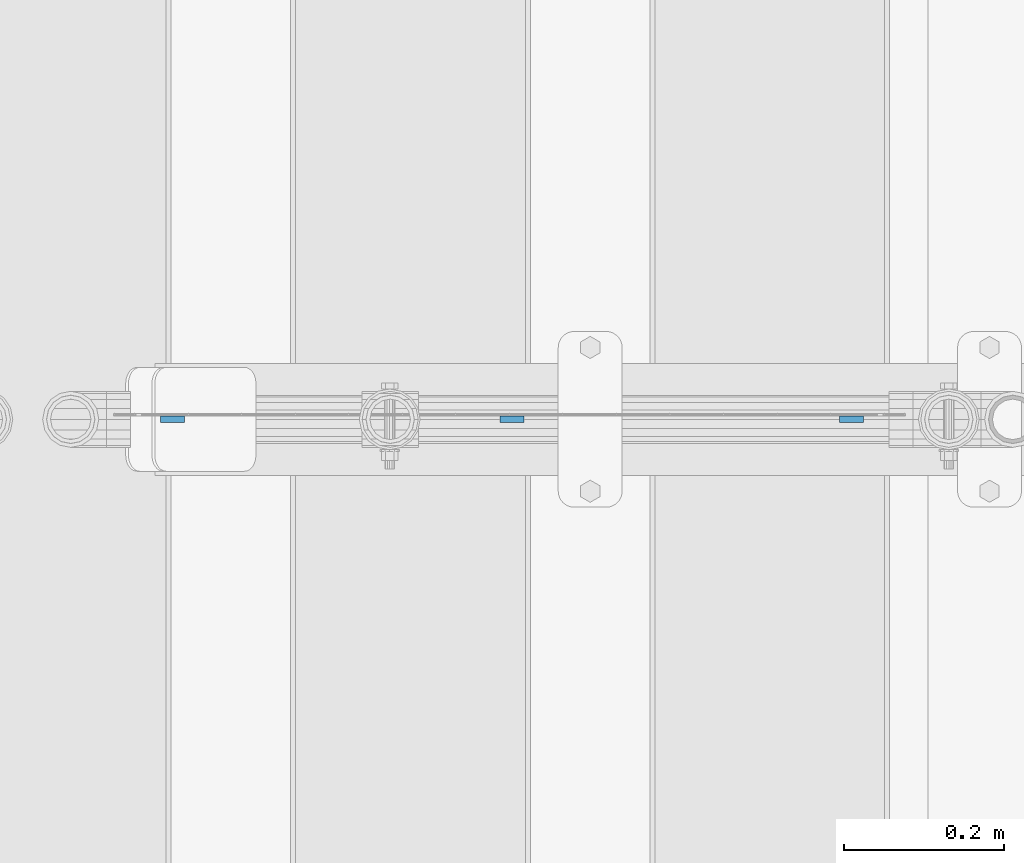
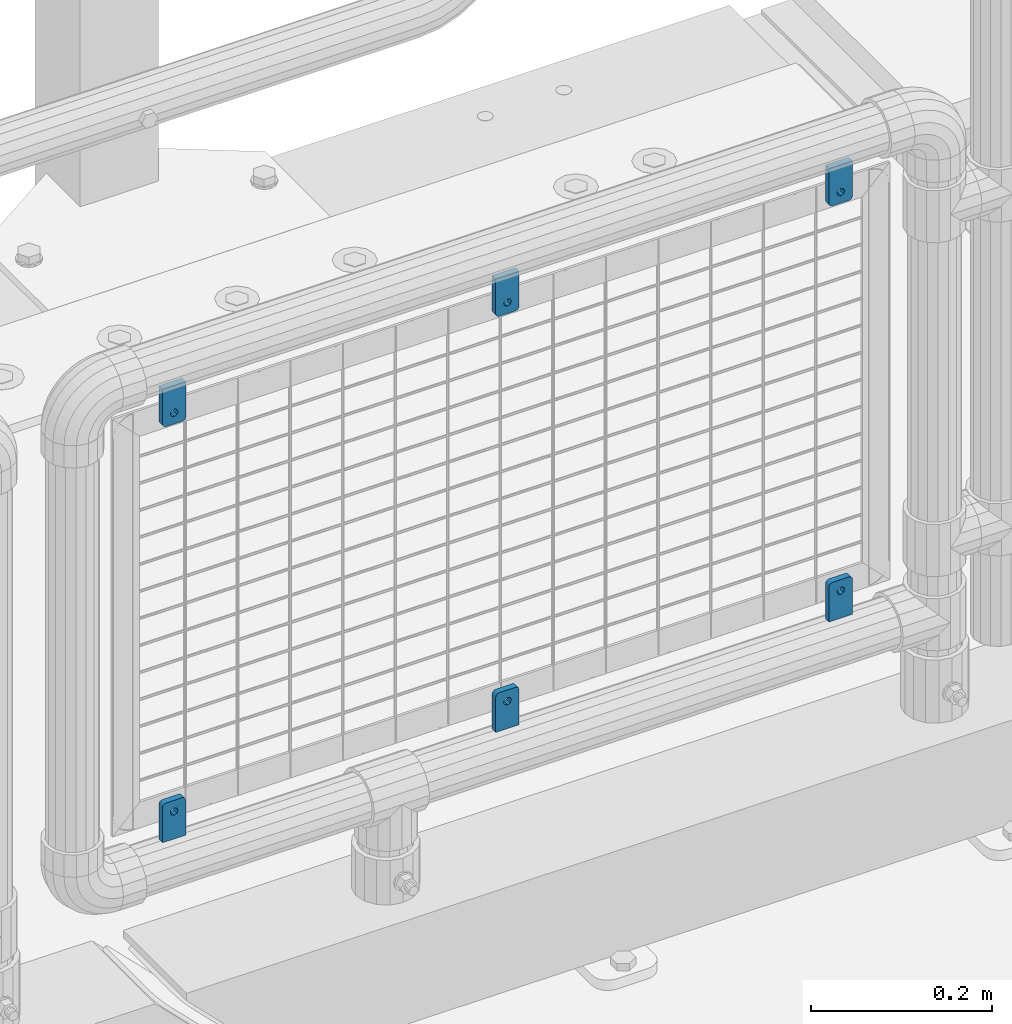
# One storey, part 266 of 270: 6 plates.
"""IFC2X3 building model written with IfcOpenShell, lengths in millimetres."""

from ifc_helpers import new_model, si_unit, frame, origin_with_axes, place, context, subcontext, project, spatial, faceted_brep, material, type_object, element, save


model = new_model("IFC2X3")

# Units and contexts
model_context = context("Model", 3, precision=1e-05, world=origin_with_axes())
body_context = subcontext(model_context, "Body", "Model", "MODEL_VIEW")
ifc_project = project(units=[si_unit("LENGTHUNIT", "METRE", prefix="MILLI"), si_unit("AREAUNIT", "SQUARE_METRE"), si_unit("VOLUMEUNIT", "CUBIC_METRE"), si_unit("MASSUNIT", "GRAM", prefix="KILO"), si_unit("TIMEUNIT", "SECOND"), si_unit("PLANEANGLEUNIT", "RADIAN"), si_unit("SOLIDANGLEUNIT", "STERADIAN"), si_unit("THERMODYNAMICTEMPERATUREUNIT", "DEGREE_CELSIUS"), si_unit("LUMINOUSINTENSITYUNIT", "LUMEN")], contexts=[model_context])

# Site, building, storey
site_placement = place(None, origin_with_axes())
site = spatial("IfcSite", under=ifc_project, at=site_placement, CompositionType="ELEMENT")
building_placement = place(site_placement, origin_with_axes())
building = spatial("IfcBuilding", under=site, at=building_placement, Name="Standard", CompositionType="ELEMENT")
storey_placement = place(building_placement, origin_with_axes())
storey = spatial("IfcBuildingStorey", under=building, at=storey_placement, Name="Undefined", CompositionType="ELEMENT", Elevation=0.0)

# Plates
ifc_material = material(Name="STEEL/S355J2")
plate_type = type_object("IfcPlateType", PredefinedType="NOTDEFINED")
plate_1_placement = place(storey_placement, frame((19262.1, -16335.5000583803, 328.320000000077), z_axis=(-1.0, 0.0, 0.0), x_axis=(0.0, 0.0, 1.0)))
element("IfcPlate", 1, at=plate_1_placement, inside=storey, type_object=plate_type, material=ifc_material, context=body_context, shape_type="Brep", body=[
    faceted_brep([(48.5450849718748, -4.0, 29.7552825814746), (49.9389262614624, -4.00000000000182, 29.0450849718727), (49.9389262614624, 3.99999999999818, 29.0450849718727), (48.5450849718748, 4.0, 29.7552825814746), (51.0450849718748, -4.00000000000182, 27.9389262614604), (51.0450849718748, 3.99999999999818, 27.9389262614604), (51.7552825814757, -4.0, 26.5450849718727), (51.7552825814757, 4.0, 26.5450849718727), (52.0, -4.00000000000182, 24.9999999999964), (52.0, 3.99999999999818, 25.0), (52.0, -4.00000000000182, 4.99999999999636), (52.0, 3.99999999999818, 5.0), (51.7552825814757, -4.0, 3.45491502812365), (51.7552825814757, 4.0, 3.45491502812365), (51.0450849718748, -4.0, 2.06107373853592), (51.0450849718748, 4.0, 2.06107373853592), (49.9389262614624, -4.0, 0.954915028123651), (49.9389262614624, 4.0, 0.954915028123651), (48.5450849718748, -4.00000000000182, 0.244717418521759), (48.5450849718748, 3.99999999999818, 0.244717418521759), (47.0, -4.0, -3.63797880709171e-12), (47.0, 4.0, 0.0), (0.0, -4.0, -3.63797880709171e-12), (0.0, 4.0, 0.0), (0.0, -4.00000000000182, 29.9999999999964), (47.0, -4.00000000000182, 29.9999999999964), (47.0, 3.99999999999818, 30.0), (0.0, 3.99999999999818, 30.0), (42.0, -4.0, 15.0000000039327), (40.5355339059328, -4.0, 11.4644660980011), (37.0, -4.0, 10.0000000039327), (33.4644660940672, -4.0, 11.4644660980011), (32.0, -4.0, 15.0000000039327), (33.4644660940672, -4.0, 18.5355339098642), (37.0, -4.0, 20.0000000039327), (40.5355339059328, -4.0, 18.5355339098642), (33.4644660940672, 3.99999999999818, 11.4644660900012), (37.0, 3.99999999999818, 9.99999999593274), (32.0, 3.99999999999818, 14.9999999959327), (33.4644660940672, 3.99999999999818, 18.5355339018643), (37.0, 3.99999999999818, 19.9999999959327), (40.5355339059328, 3.99999999999818, 18.5355339018643), (42.0, 3.99999999999818, 14.9999999959327), (40.5355339059328, 3.99999999999818, 11.4644660900012)], [[[0, 1, 2, 3]], [[1, 4, 5, 2]], [[4, 6, 7, 5]], [[6, 8, 9, 7]], [[8, 10, 11, 9]], [[10, 12, 13, 11]], [[12, 14, 15, 13]], [[14, 16, 17, 15]], [[16, 18, 19, 17]], [[18, 20, 21, 19]], [[20, 22, 23, 21]], [[24, 25, 26, 27]], [[22, 24, 27, 23]], [[20, 18, 16, 14, 12, 10, 8, 6, 4, 1, 0, 25, 24, 22], [28, 29, 30, 31, 32, 33, 34, 35]], [[36, 31, 30, 37]], [[38, 32, 31, 36]], [[39, 33, 32, 38]], [[40, 34, 33, 39]], [[41, 35, 34, 40]], [[42, 28, 35, 41]], [[43, 29, 28, 42]], [[37, 30, 29, 43]], [[26, 3, 2, 5, 7, 9, 11, 13, 15, 17, 19, 21, 23, 27], [38, 36, 37, 43, 42, 41, 40, 39]], [[25, 0, 3, 26]]]),
])
plate_2_placement = place(storey_placement, frame((19232.1, -16335.5000583803, 939.699999999924), z_axis=(1.0, 0.0, 0.0), x_axis=(0.0, 0.0, -1.0)))
element("IfcPlate", 2, at=plate_2_placement, inside=storey, type_object=plate_type, material=ifc_material, context=body_context, shape_type="Brep", body=[
    faceted_brep([(48.5450849718748, -4.0, 29.7552825814746), (49.9389262614624, -4.00000000000182, 29.0450849718727), (49.9389262614624, 3.99999999999818, 29.0450849718727), (48.5450849718748, 4.0, 29.7552825814746), (51.0450849718748, -4.00000000000182, 27.9389262614604), (51.0450849718748, 3.99999999999818, 27.9389262614604), (51.7552825814757, -4.0, 26.5450849718727), (51.7552825814757, 4.0, 26.5450849718727), (52.0, -4.00000000000182, 24.9999999999964), (52.0, 3.99999999999818, 25.0), (52.0, -4.00000000000182, 4.99999999999636), (52.0, 3.99999999999818, 5.0), (51.7552825814757, -4.0, 3.45491502812365), (51.7552825814757, 4.0, 3.45491502812365), (51.0450849718748, -4.0, 2.06107373853592), (51.0450849718748, 4.0, 2.06107373853592), (49.9389262614624, -4.0, 0.954915028123651), (49.9389262614624, 4.0, 0.954915028123651), (48.5450849718748, -4.00000000000182, 0.244717418521759), (48.5450849718748, 3.99999999999818, 0.244717418521759), (47.0, -4.0, -3.63797880709171e-12), (47.0, 4.0, 0.0), (0.0, -4.0, -3.63797880709171e-12), (0.0, 4.0, 0.0), (0.0, -4.00000000000182, 29.9999999999964), (47.0, -4.00000000000182, 29.9999999999964), (47.0, 3.99999999999818, 30.0), (0.0, 3.99999999999818, 30.0), (42.0, -4.0, 15.0000000039327), (40.5355339059328, -4.0, 11.4644660980011), (37.0, -4.0, 10.0000000039327), (33.4644660940672, -4.0, 11.4644660980011), (32.0, -4.0, 15.0000000039327), (33.4644660940672, -4.0, 18.5355339098642), (37.0, -4.0, 20.0000000039327), (40.5355339059328, -4.0, 18.5355339098642), (40.5355339059328, 3.99999999999818, 18.5355339018643), (37.0, 3.99999999999818, 19.9999999959327), (42.0, 3.99999999999818, 14.9999999959327), (40.5355339059328, 3.99999999999818, 11.4644660900012), (37.0, 3.99999999999818, 9.99999999593274), (33.4644660940672, 3.99999999999818, 11.4644660900012), (32.0, 3.99999999999818, 14.9999999959327), (33.4644660940672, 3.99999999999818, 18.5355339018643)], [[[0, 1, 2, 3]], [[1, 4, 5, 2]], [[4, 6, 7, 5]], [[6, 8, 9, 7]], [[8, 10, 11, 9]], [[10, 12, 13, 11]], [[12, 14, 15, 13]], [[14, 16, 17, 15]], [[16, 18, 19, 17]], [[18, 20, 21, 19]], [[20, 22, 23, 21]], [[24, 25, 26, 27]], [[22, 24, 27, 23]], [[20, 18, 16, 14, 12, 10, 8, 6, 4, 1, 0, 25, 24, 22], [28, 29, 30, 31, 32, 33, 34, 35]], [[36, 35, 34, 37]], [[38, 28, 35, 36]], [[39, 29, 28, 38]], [[40, 30, 29, 39]], [[41, 31, 30, 40]], [[42, 32, 31, 41]], [[43, 33, 32, 42]], [[37, 34, 33, 43]], [[26, 3, 2, 5, 7, 9, 11, 13, 15, 17, 19, 21, 23, 27], [42, 41, 40, 39, 38, 36, 37, 43]], [[25, 0, 3, 26]]]),
])
plate_3_placement = place(storey_placement, frame((18837.1, -16335.5000583803, 328.320000000077), z_axis=(-1.0, 0.0, 0.0), x_axis=(0.0, 0.0, 1.0)))
element("IfcPlate", 3, at=plate_3_placement, inside=storey, type_object=plate_type, material=ifc_material, context=body_context, shape_type="Brep", body=[
    faceted_brep([(48.5450849718748, -4.0, 29.7552825814746), (49.9389262614624, -4.00000000000182, 29.0450849718727), (49.9389262614624, 3.99999999999818, 29.0450849718727), (48.5450849718748, 4.0, 29.7552825814746), (51.0450849718748, -4.00000000000182, 27.9389262614604), (51.0450849718748, 3.99999999999818, 27.9389262614604), (51.7552825814757, -4.0, 26.5450849718727), (51.7552825814757, 4.0, 26.5450849718727), (52.0, -4.00000000000182, 24.9999999999964), (52.0, 3.99999999999818, 25.0), (52.0, -4.00000000000182, 4.99999999999636), (52.0, 3.99999999999818, 5.0), (51.7552825814757, -4.0, 3.45491502812365), (51.7552825814757, 4.0, 3.45491502812365), (51.0450849718748, -4.0, 2.06107373853592), (51.0450849718748, 4.0, 2.06107373853592), (49.9389262614624, -4.0, 0.954915028123651), (49.9389262614624, 4.0, 0.954915028123651), (48.5450849718748, -4.00000000000182, 0.244717418521759), (48.5450849718748, 3.99999999999818, 0.244717418521759), (47.0, -4.0, -3.63797880709171e-12), (47.0, 4.0, 0.0), (0.0, -4.0, -3.63797880709171e-12), (0.0, 4.0, 0.0), (0.0, -4.00000000000182, 29.9999999999964), (47.0, -4.00000000000182, 29.9999999999964), (47.0, 3.99999999999818, 30.0), (0.0, 3.99999999999818, 30.0), (42.0, -4.0, 15.0000000039327), (40.5355339059328, -4.0, 11.4644660980011), (37.0, -4.0, 10.0000000039327), (33.4644660940672, -4.0, 11.4644660980011), (32.0, -4.0, 15.0000000039327), (33.4644660940672, -4.0, 18.5355339098642), (37.0, -4.0, 20.0000000039327), (40.5355339059328, -4.0, 18.5355339098642), (33.4644660940672, 3.99999999999818, 11.4644660900012), (37.0, 3.99999999999818, 9.99999999593274), (32.0, 3.99999999999818, 14.9999999959327), (33.4644660940672, 3.99999999999818, 18.5355339018643), (37.0, 3.99999999999818, 19.9999999959327), (40.5355339059328, 3.99999999999818, 18.5355339018643), (42.0, 3.99999999999818, 14.9999999959327), (40.5355339059328, 3.99999999999818, 11.4644660900012)], [[[0, 1, 2, 3]], [[1, 4, 5, 2]], [[4, 6, 7, 5]], [[6, 8, 9, 7]], [[8, 10, 11, 9]], [[10, 12, 13, 11]], [[12, 14, 15, 13]], [[14, 16, 17, 15]], [[16, 18, 19, 17]], [[18, 20, 21, 19]], [[20, 22, 23, 21]], [[24, 25, 26, 27]], [[22, 24, 27, 23]], [[20, 18, 16, 14, 12, 10, 8, 6, 4, 1, 0, 25, 24, 22], [28, 29, 30, 31, 32, 33, 34, 35]], [[36, 31, 30, 37]], [[38, 32, 31, 36]], [[39, 33, 32, 38]], [[40, 34, 33, 39]], [[41, 35, 34, 40]], [[42, 28, 35, 41]], [[43, 29, 28, 42]], [[37, 30, 29, 43]], [[26, 3, 2, 5, 7, 9, 11, 13, 15, 17, 19, 21, 23, 27], [38, 36, 37, 43, 42, 41, 40, 39]], [[25, 0, 3, 26]]]),
])
plate_4_placement = place(storey_placement, frame((18807.1, -16335.5000583803, 939.699999999924), z_axis=(1.0, 0.0, 0.0), x_axis=(0.0, 0.0, -1.0)))
element("IfcPlate", 4, at=plate_4_placement, inside=storey, type_object=plate_type, material=ifc_material, context=body_context, shape_type="Brep", body=[
    faceted_brep([(48.5450849718748, -4.0, 29.7552825814746), (49.9389262614624, -4.00000000000182, 29.0450849718727), (49.9389262614624, 3.99999999999818, 29.0450849718727), (48.5450849718748, 4.0, 29.7552825814746), (51.0450849718748, -4.00000000000182, 27.9389262614604), (51.0450849718748, 3.99999999999818, 27.9389262614604), (51.7552825814757, -4.0, 26.5450849718727), (51.7552825814757, 4.0, 26.5450849718727), (52.0, -4.00000000000182, 24.9999999999964), (52.0, 3.99999999999818, 25.0), (52.0, -4.00000000000182, 4.99999999999636), (52.0, 3.99999999999818, 5.0), (51.7552825814757, -4.0, 3.45491502812365), (51.7552825814757, 4.0, 3.45491502812365), (51.0450849718748, -4.0, 2.06107373853592), (51.0450849718748, 4.0, 2.06107373853592), (49.9389262614624, -4.0, 0.954915028123651), (49.9389262614624, 4.0, 0.954915028123651), (48.5450849718748, -4.00000000000182, 0.244717418521759), (48.5450849718748, 3.99999999999818, 0.244717418521759), (47.0, -4.0, -3.63797880709171e-12), (47.0, 4.0, 0.0), (0.0, -4.0, -3.63797880709171e-12), (0.0, 4.0, 0.0), (0.0, -4.00000000000182, 29.9999999999964), (47.0, -4.00000000000182, 29.9999999999964), (47.0, 3.99999999999818, 30.0), (0.0, 3.99999999999818, 30.0), (42.0, -4.0, 15.0000000039327), (40.5355339059328, -4.0, 11.4644660980011), (37.0, -4.0, 10.0000000039327), (33.4644660940672, -4.0, 11.4644660980011), (32.0, -4.0, 15.0000000039327), (33.4644660940672, -4.0, 18.5355339098642), (37.0, -4.0, 20.0000000039327), (40.5355339059328, -4.0, 18.5355339098642), (40.5355339059328, 3.99999999999818, 18.5355339018643), (37.0, 3.99999999999818, 19.9999999959327), (42.0, 3.99999999999818, 14.9999999959327), (40.5355339059328, 3.99999999999818, 11.4644660900012), (37.0, 3.99999999999818, 9.99999999593274), (33.4644660940672, 3.99999999999818, 11.4644660900012), (32.0, 3.99999999999818, 14.9999999959327), (33.4644660940672, 3.99999999999818, 18.5355339018643)], [[[0, 1, 2, 3]], [[1, 4, 5, 2]], [[4, 6, 7, 5]], [[6, 8, 9, 7]], [[8, 10, 11, 9]], [[10, 12, 13, 11]], [[12, 14, 15, 13]], [[14, 16, 17, 15]], [[16, 18, 19, 17]], [[18, 20, 21, 19]], [[20, 22, 23, 21]], [[24, 25, 26, 27]], [[22, 24, 27, 23]], [[20, 18, 16, 14, 12, 10, 8, 6, 4, 1, 0, 25, 24, 22], [28, 29, 30, 31, 32, 33, 34, 35]], [[36, 35, 34, 37]], [[38, 28, 35, 36]], [[39, 29, 28, 38]], [[40, 30, 29, 39]], [[41, 31, 30, 40]], [[42, 32, 31, 41]], [[43, 33, 32, 42]], [[37, 34, 33, 43]], [[26, 3, 2, 5, 7, 9, 11, 13, 15, 17, 19, 21, 23, 27], [42, 41, 40, 39, 38, 36, 37, 43]], [[25, 0, 3, 26]]]),
])
plate_5_placement = place(storey_placement, frame((19687.1, -16335.5000583803, 328.320000000077), z_axis=(-1.0, 0.0, 0.0), x_axis=(0.0, 0.0, 1.0)))
element("IfcPlate", 5, at=plate_5_placement, inside=storey, type_object=plate_type, material=ifc_material, context=body_context, shape_type="Brep", body=[
    faceted_brep([(48.5450849718748, -4.0, 29.7552825814746), (49.9389262614624, -4.00000000000182, 29.0450849718727), (49.9389262614624, 3.99999999999818, 29.0450849718727), (48.5450849718748, 4.0, 29.7552825814746), (51.0450849718748, -4.00000000000182, 27.9389262614604), (51.0450849718748, 3.99999999999818, 27.9389262614604), (51.7552825814757, -4.0, 26.5450849718727), (51.7552825814757, 4.0, 26.5450849718727), (52.0, -4.00000000000182, 24.9999999999964), (52.0, 3.99999999999818, 25.0), (52.0, -4.00000000000182, 4.99999999999636), (52.0, 3.99999999999818, 5.0), (51.7552825814757, -4.0, 3.45491502812365), (51.7552825814757, 4.0, 3.45491502812365), (51.0450849718748, -4.0, 2.06107373853592), (51.0450849718748, 4.0, 2.06107373853592), (49.9389262614624, -4.0, 0.954915028123651), (49.9389262614624, 4.0, 0.954915028123651), (48.5450849718748, -4.00000000000182, 0.244717418521759), (48.5450849718748, 3.99999999999818, 0.244717418521759), (47.0, -4.0, -3.63797880709171e-12), (47.0, 4.0, 0.0), (0.0, -4.0, -3.63797880709171e-12), (0.0, 4.0, 0.0), (0.0, -4.00000000000182, 29.9999999999964), (47.0, -4.00000000000182, 29.9999999999964), (47.0, 3.99999999999818, 30.0), (0.0, 3.99999999999818, 30.0), (42.0, -4.0, 15.0000000039327), (40.5355339059328, -4.0, 11.4644660980011), (37.0, -4.0, 10.0000000039327), (33.4644660940672, -4.0, 11.4644660980011), (32.0, -4.0, 15.0000000039327), (33.4644660940672, -4.0, 18.5355339098642), (37.0, -4.0, 20.0000000039327), (40.5355339059328, -4.0, 18.5355339098642), (33.4644660940672, 3.99999999999818, 11.4644660900012), (37.0, 3.99999999999818, 9.99999999593274), (32.0, 3.99999999999818, 14.9999999959327), (33.4644660940672, 3.99999999999818, 18.5355339018643), (37.0, 3.99999999999818, 19.9999999959327), (40.5355339059328, 3.99999999999818, 18.5355339018643), (42.0, 3.99999999999818, 14.9999999959327), (40.5355339059328, 3.99999999999818, 11.4644660900012)], [[[0, 1, 2, 3]], [[1, 4, 5, 2]], [[4, 6, 7, 5]], [[6, 8, 9, 7]], [[8, 10, 11, 9]], [[10, 12, 13, 11]], [[12, 14, 15, 13]], [[14, 16, 17, 15]], [[16, 18, 19, 17]], [[18, 20, 21, 19]], [[20, 22, 23, 21]], [[24, 25, 26, 27]], [[22, 24, 27, 23]], [[20, 18, 16, 14, 12, 10, 8, 6, 4, 1, 0, 25, 24, 22], [28, 29, 30, 31, 32, 33, 34, 35]], [[36, 31, 30, 37]], [[38, 32, 31, 36]], [[39, 33, 32, 38]], [[40, 34, 33, 39]], [[41, 35, 34, 40]], [[42, 28, 35, 41]], [[43, 29, 28, 42]], [[37, 30, 29, 43]], [[26, 3, 2, 5, 7, 9, 11, 13, 15, 17, 19, 21, 23, 27], [38, 36, 37, 43, 42, 41, 40, 39]], [[25, 0, 3, 26]]]),
])
plate_6_placement = place(storey_placement, frame((19657.1, -16335.5000583803, 939.699999999924), z_axis=(1.0, 0.0, 0.0), x_axis=(0.0, 0.0, -1.0)))
element("IfcPlate", 6, at=plate_6_placement, inside=storey, type_object=plate_type, material=ifc_material, context=body_context, shape_type="Brep", body=[
    faceted_brep([(48.5450849718748, -4.0, 29.7552825814746), (49.9389262614624, -4.00000000000182, 29.0450849718727), (49.9389262614624, 3.99999999999818, 29.0450849718727), (48.5450849718748, 4.0, 29.7552825814746), (51.0450849718748, -4.00000000000182, 27.9389262614604), (51.0450849718748, 3.99999999999818, 27.9389262614604), (51.7552825814757, -4.0, 26.5450849718727), (51.7552825814757, 4.0, 26.5450849718727), (52.0, -4.00000000000182, 24.9999999999964), (52.0, 3.99999999999818, 25.0), (52.0, -4.00000000000182, 4.99999999999636), (52.0, 3.99999999999818, 5.0), (51.7552825814757, -4.0, 3.45491502812365), (51.7552825814757, 4.0, 3.45491502812365), (51.0450849718748, -4.0, 2.06107373853592), (51.0450849718748, 4.0, 2.06107373853592), (49.9389262614624, -4.0, 0.954915028123651), (49.9389262614624, 4.0, 0.954915028123651), (48.5450849718748, -4.00000000000182, 0.244717418521759), (48.5450849718748, 3.99999999999818, 0.244717418521759), (47.0, -4.0, -3.63797880709171e-12), (47.0, 4.0, 0.0), (0.0, -4.0, -3.63797880709171e-12), (0.0, 4.0, 0.0), (0.0, -4.00000000000182, 29.9999999999964), (47.0, -4.00000000000182, 29.9999999999964), (47.0, 3.99999999999818, 30.0), (0.0, 3.99999999999818, 30.0), (42.0, -4.0, 15.0000000039327), (40.5355339059328, -4.0, 11.4644660980011), (37.0, -4.0, 10.0000000039327), (33.4644660940672, -4.0, 11.4644660980011), (32.0, -4.0, 15.0000000039327), (33.4644660940672, -4.0, 18.5355339098642), (37.0, -4.0, 20.0000000039327), (40.5355339059328, -4.0, 18.5355339098642), (40.5355339059328, 3.99999999999818, 18.5355339018643), (37.0, 3.99999999999818, 19.9999999959327), (42.0, 3.99999999999818, 14.9999999959327), (40.5355339059328, 3.99999999999818, 11.4644660900012), (37.0, 3.99999999999818, 9.99999999593274), (33.4644660940672, 3.99999999999818, 11.4644660900012), (32.0, 3.99999999999818, 14.9999999959327), (33.4644660940672, 3.99999999999818, 18.5355339018643)], [[[0, 1, 2, 3]], [[1, 4, 5, 2]], [[4, 6, 7, 5]], [[6, 8, 9, 7]], [[8, 10, 11, 9]], [[10, 12, 13, 11]], [[12, 14, 15, 13]], [[14, 16, 17, 15]], [[16, 18, 19, 17]], [[18, 20, 21, 19]], [[20, 22, 23, 21]], [[24, 25, 26, 27]], [[22, 24, 27, 23]], [[20, 18, 16, 14, 12, 10, 8, 6, 4, 1, 0, 25, 24, 22], [28, 29, 30, 31, 32, 33, 34, 35]], [[36, 35, 34, 37]], [[38, 28, 35, 36]], [[39, 29, 28, 38]], [[40, 30, 29, 39]], [[41, 31, 30, 40]], [[42, 32, 31, 41]], [[43, 33, 32, 42]], [[37, 34, 33, 43]], [[26, 3, 2, 5, 7, 9, 11, 13, 15, 17, 19, 21, 23, 27], [42, 41, 40, 39, 38, 36, 37, 43]], [[25, 0, 3, 26]]]),
])

save(model, "model.ifc")
